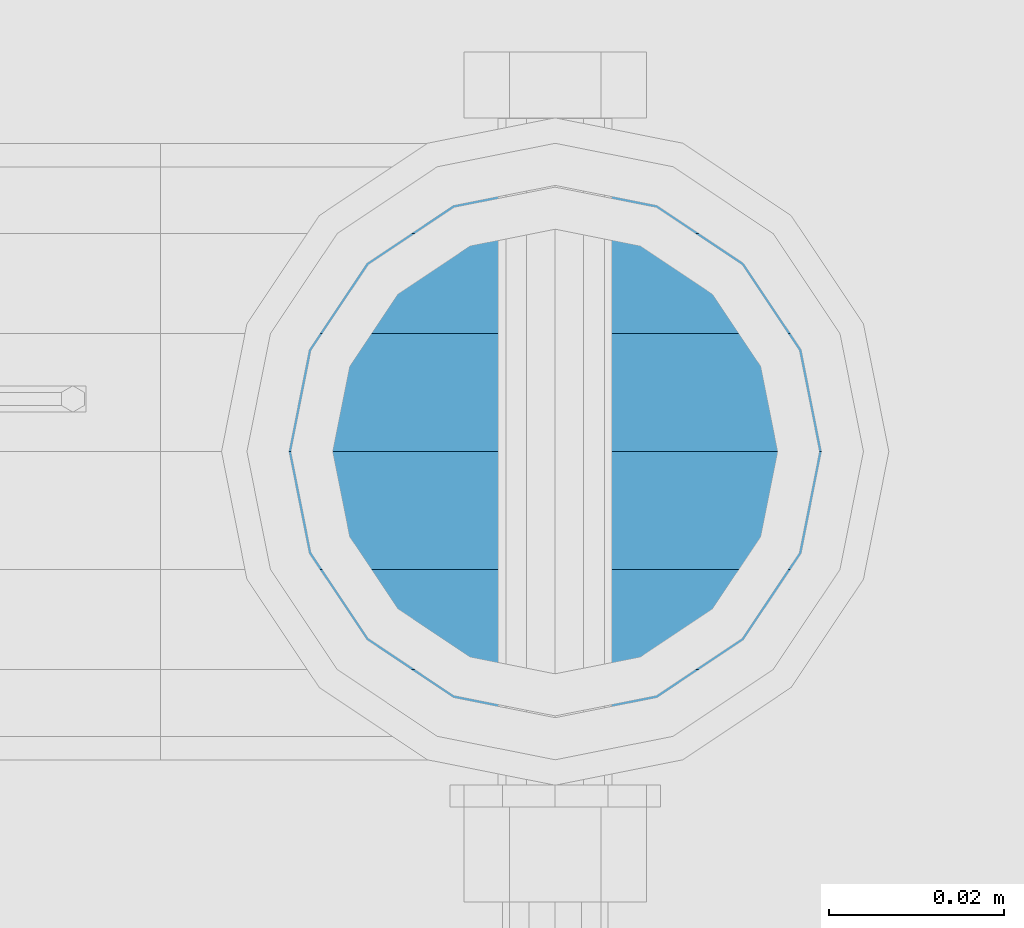
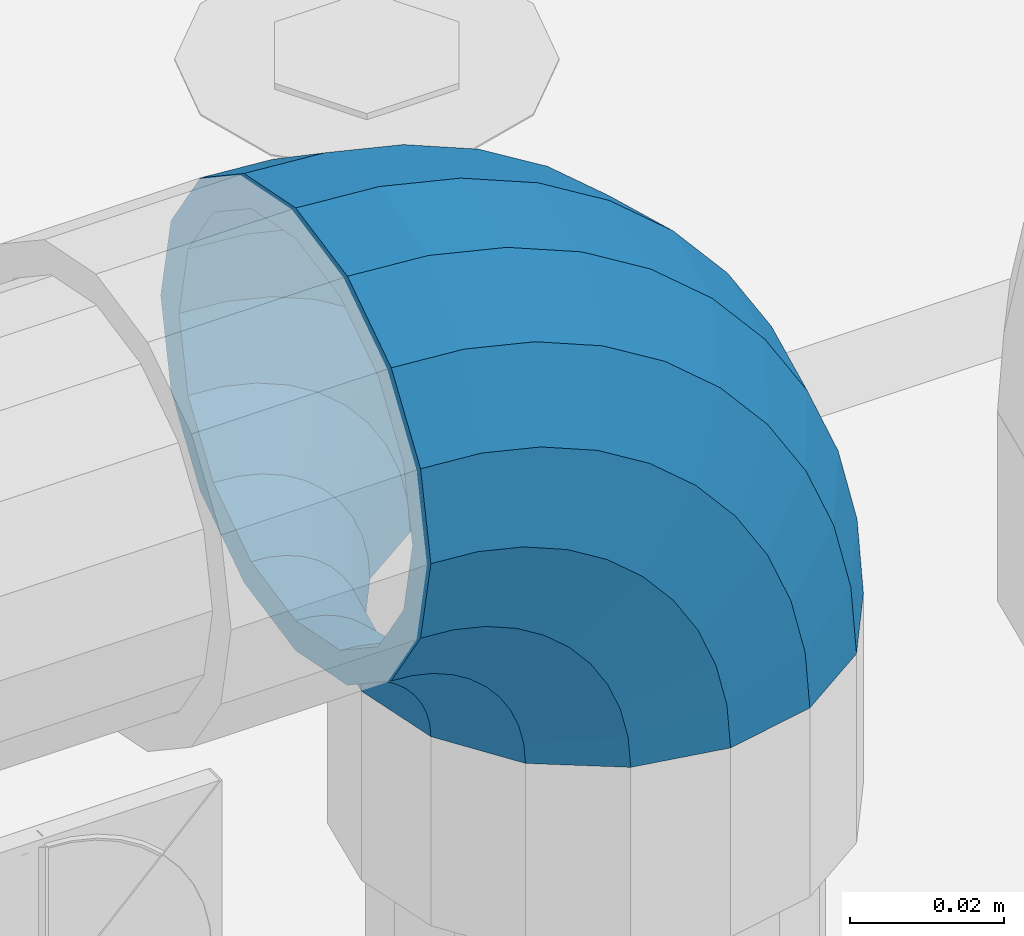
# One storey, part 138 of 208: 1 member.
"""IFC2X3 building model written with IfcOpenShell, lengths in millimetres."""

from ifc_helpers import new_model, si_unit, frame, origin_with_axes, place, context, subcontext, project, spatial, faceted_brep, material, type_object, element, save


model = new_model("IFC2X3")

# Units and contexts
model_context = context("Model", 3, precision=1e-05, world=origin_with_axes())
body_context = subcontext(model_context, "Body", "Model", "MODEL_VIEW")
ifc_project = project(units=[si_unit("LENGTHUNIT", "METRE", prefix="MILLI"), si_unit("AREAUNIT", "SQUARE_METRE"), si_unit("VOLUMEUNIT", "CUBIC_METRE"), si_unit("MASSUNIT", "GRAM", prefix="KILO"), si_unit("TIMEUNIT", "SECOND"), si_unit("PLANEANGLEUNIT", "RADIAN"), si_unit("SOLIDANGLEUNIT", "STERADIAN"), si_unit("THERMODYNAMICTEMPERATUREUNIT", "DEGREE_CELSIUS"), si_unit("LUMINOUSINTENSITYUNIT", "LUMEN")], contexts=[model_context])

# Site, building, storey
site_placement = place(None, origin_with_axes())
site = spatial("IfcSite", under=ifc_project, at=site_placement, CompositionType="ELEMENT")
building_placement = place(site_placement, origin_with_axes())
building = spatial("IfcBuilding", under=site, at=building_placement, Name="Standard", CompositionType="ELEMENT")
storey_placement = place(building_placement, origin_with_axes())
storey = spatial("IfcBuildingStorey", under=building, at=storey_placement, Name="Undefined", CompositionType="ELEMENT", Elevation=0.0)

# Member
ifc_material = material(Name="Misc_Undefined")
member_type = type_object("IfcMemberType", PredefinedType="NOTDEFINED")
member_placement = place(storey_placement, frame((-27429.0, 4664.5, 924.85), z_axis=(0.707106781186539, -1.49999999888231e-07, 0.70710678118654), x_axis=(-0.707106781186548, 0.0, 0.707106781186548)))
element("IfcMember", 1, at=member_placement, inside=storey, type_object=member_type, material=ifc_material, context=body_context, shape_type="Brep", body=[
    faceted_brep([(0.0, -35.1499999999996, 0.0), (9.51152146007371, -32.4743655677721, -9.51152146006643), (13.2759578763435, -32.4743655677721, -6.29638902527222), (5.3694688002397, -35.1499999999996, 4.58595959348168), (17.5750000000044, -24.8548033587067, -17.5749999999971), (19.9787556631163, -24.8548033587067, -15.5219987155615), (22.9628441077075, -13.4513226476329, -22.9628441076966), (24.4574219585302, -13.4513226476329, -21.6863540323902), (24.854803358714, 0.0, -24.8548033587031), (26.0301204183197, 0.0, -23.8509877588003), (22.9628441077075, 13.4513226476329, -22.9628441076966), (24.4574219585302, 13.4513226476329, -21.6863540323902), (17.5750000000044, 24.8548033587067, -17.5749999999971), (19.9787556631163, 24.8548033587067, -15.5219987155615), (9.51152146007371, 32.4743655677721, -9.51152146006643), (13.2759578763435, 32.4743655677721, -6.29638902527222), (0.0, 35.1499999999996, 0.0), (5.3694688002397, 35.1499999999996, 4.58595959348168), (-9.51152146006643, 32.4743655677721, 9.51152146007371), (-2.53702027587133, 32.4743655677721, 15.4683082122356), (-17.5749999999935, 24.8548033587067, 17.5750000000044), (-9.23981806264055, 24.8548033587067, 24.6939179025248), (-22.9628441076966, 13.4513226476329, 22.9628441077039), (-13.7184843580508, 13.4513226476329, 30.8582732193536), (-24.8548033587031, 0.0, 24.854803358714), (-15.2911828178439, 0.0, 33.02290694576), (-22.9628441076966, -13.4513226476329, 22.9628441077039), (-13.7184843580508, -13.4513226476329, 30.8582732193536), (-17.5749999999935, -24.8548033587067, 17.5750000000044), (-9.23981806264055, -24.8548033587067, 24.6939179025248), (-9.51152146006643, -32.4743655677721, 9.51152146007371), (-2.53702027587133, -32.4743655677721, 15.4683082122356), (0.0, -30.3500000000004, 0.0), (-8.21265081971433, -28.0397438117179, 8.21265081972524), (-1.45732902223244, -28.0397438117179, 13.9822406910389), (5.3694688002397, -30.3500000000004, 4.58595959348168), (-15.1749999999956, -21.4606908090118, 15.1750000000029), (-7.24480876130838, -21.4606908090118, 21.9480231689995), (-19.8270929919963, -11.6144421722802, 19.8270929920036), (-11.1118790903529, -11.6144421722802, 27.2705888550809), (-21.4606908090063, 0.0, 21.4606908090136), (-12.46981360684, 0.0, 29.139625372758), (-19.8270929919963, 11.6144421722802, 19.8270929920036), (-11.1118790903529, 11.6144421722802, 27.2705888550809), (-15.1749999999956, 21.4606908090118, 15.1750000000029), (-7.24480876130838, 21.4606908090118, 21.9480231689995), (-8.21265081971433, 28.0397438117179, 8.21265081972524), (-1.45732902223244, 28.0397438117179, 13.9822406910389), (0.0, 30.3500000000004, 0.0), (5.3694688002397, 30.3500000000004, 4.58595959348168), (8.21265081972524, 28.0397438117179, -8.21265081971433), (12.1962666227082, 28.0397438117179, -4.81032150407918), (15.1750000000029, 21.4606908090118, -15.1749999999956), (17.9837463617841, 21.4606908090118, -12.7761039820325), (19.8270929920036, 11.6144421722802, -19.8270929919963), (21.850816690825, 11.6144421722802, -18.0986696681175), (21.4606908090136, 0.0, -21.4606908090063), (23.2087512073158, 0.0, -19.9677061857983), (19.8270929920036, -11.6144421722802, -19.8270929919963), (21.850816690825, -11.6144421722802, -18.0986696681175), (15.1750000000029, -21.4606908090118, -15.1749999999956), (17.9837463617841, -21.4606908090118, -12.7761039820325), (8.21265081972524, -28.0397438117179, -8.21265081971433), (12.1962666227082, -28.0397438117179, -4.81032150407918), (17.4970053560755, -32.4743655677721, -3.70972780291777), (11.3902326651187, -35.1499999999996, 8.27548843508339), (22.6740772628655, -24.8548033587067, -13.870303514941), (26.1332861179544, -13.4513226476329, -20.6593831546779), (27.3479987309656, 0.0, -23.0433908901359), (26.1332861179544, 13.4513226476329, -20.6593831546779), (22.6740772628655, 24.8548033587067, -13.870303514941), (17.4970053560755, 32.4743655677721, -3.70972780291777), (11.3902326651187, 35.1499999999996, 8.27548843508339), (5.28345997416181, 32.4743655677721, 20.2607046730918), (0.106388067368243, 24.8548033587067, 30.4212803851115), (-3.3528207877207, 13.4513226476329, 37.2103600248483), (-4.56753340072828, 0.0, 39.59436776031), (-3.3528207877207, -13.4513226476329, 37.2103600248483), (0.106388067368243, -24.8548033587067, 30.4212803851115), (5.28345997416181, -32.4743655677721, 20.2607046730918), (6.11738625912767, -28.0397438117179, 18.6240321853948), (11.3902326651187, -30.3500000000004, 8.27548843508339), (1.64728291998108, -21.4606908090118, 27.3971039595053), (-1.33954464053022, -11.6144421722802, 33.2590831078996), (-2.38837900197541, 0.0, 35.3175364441995), (-1.33954464053022, 11.6144421722802, 33.2590831078996), (1.64728291998108, 21.4606908090118, 27.3971039595053), (6.11738625912767, 28.0397438117179, 18.6240321853948), (11.3902326651187, 30.3500000000004, 8.27548843508339), (16.663079071106, 28.0397438117179, -2.07305531522434), (21.1331824102563, 21.4606908090118, -10.8461270893349), (24.1200099707712, 11.6144421722802, -16.7081062377256), (25.1688443322128, 0.0, -18.7665595740327), (24.1200099707712, -11.6144421722802, -16.7081062377256), (21.1331824102563, -21.4606908090118, -10.8461270893349), (16.663079071106, -28.0397438117179, -2.07305531522434), (22.0707277014626, -32.4743655677721, -1.81522997692809), (17.9140404065256, -35.1499999999996, 10.9777380798914), (25.5945970362154, -24.8548033587067, -12.6605846156417), (27.9491712485142, -13.4513226476329, -19.9072189058897), (28.7759877588032, 0.0, -22.4518984678834), (27.9491712485142, 13.4513226476329, -19.9072189058897), (25.5945970362154, 24.8548033587067, -12.6605846156417), (22.0707277014626, 32.4743655677721, -1.81522997692809), (17.9140404065256, 35.1499999999996, 10.9777380798914), (13.7573531115886, 32.4743655677721, 23.7707061367109), (10.2334837768358, 24.8548033587067, 34.6160607754246), (7.87890956454066, 13.4513226476329, 41.8626950656726), (7.05209305424796, 0.0, 44.4073746276663), (7.87890956454066, -13.4513226476329, 41.8626950656726), (10.2334837768358, -24.8548033587067, 34.6160607754246), (13.7573531115886, -32.4743655677721, 23.7707061367109), (14.3249803951076, -28.0397438117179, 22.023728990971), (17.9140404065256, -30.3500000000004, 10.9777380798914), (11.2823222355146, -21.4606908090118, 31.3880679180002), (9.2492830507872, -11.6144421722802, 37.6451191472734), (8.53537462724489, 0.0, 39.8423033494473), (9.2492830507872, 11.6144421722802, 37.6451191472734), (11.2823222355146, 21.4606908090118, 31.3880679180002), (14.3249803951076, 28.0397438117179, 22.023728990971), (17.9140404065256, 30.3500000000004, 10.9777380798914), (21.5031004179436, 28.0397438117179, -0.0682528311917849), (24.5457585775366, 21.4606908090118, -9.43259175821368), (26.5787977622676, 11.6144421722802, -15.6896429874905), (27.2927061858063, 0.0, -17.8868271896645), (26.5787977622676, -11.6144421722802, -15.6896429874905), (24.5457585775366, -21.4606908090118, -9.43259175821368), (21.5031004179436, -28.0397438117179, -0.0682528311917849), (26.8845046890528, -32.4743655677721, -0.659544371261291), (24.7802542265854, -35.1499999999996, 12.6261701733893), (28.6684020936882, -24.8548033587067, -11.9226293117899), (29.860364231703, -13.4513226476329, -19.4483820661189), (30.2789256727519, 0.0, -22.0910749985305), (29.860364231703, 13.4513226476329, -19.4483820661189), (28.6684020936882, 24.8548033587067, -11.9226293117899), (26.8845046890528, 32.4743655677721, -0.659544371261291), (24.7802542265854, 35.1499999999996, 12.6261701733893), (22.6760037641179, 32.4743655677721, 25.9118847180434), (20.8921063594898, 24.8548033587067, 37.1749696585721), (19.7001442214714, 13.4513226476329, 44.7007224129011), (19.2815827804225, 0.0, 47.343415345309), (19.7001442214714, -13.4513226476329, 44.7007224129011), (20.8921063594898, -24.8548033587067, 37.1749696585721), (22.6760037641179, -32.4743655677721, 25.9118847180434), (22.9633551786246, -28.0397438117179, 24.0976192894668), (24.7802542265854, -30.3500000000004, 12.6261701733893), (21.4230625404853, -21.4606908090118, 33.8226442665691), (20.3938719035395, -11.6144421722802, 40.3206982094998), (20.0324682126193, 0.0, 42.6025113104552), (20.3938719035395, 11.6144421722802, 40.3206982094998), (21.4230625404853, 21.4606908090118, 33.8226442665691), (22.9633551786246, 28.0397438117179, 24.0976192894668), (24.7802542265854, 30.3500000000004, 12.6261701733893), (26.5971532745498, 28.0397438117179, 1.15472105731169), (28.1374459126891, 21.4606908090118, -8.5703039197906), (29.1666365496385, 11.6144421722802, -15.0683578627177), (29.5280402405588, 0.0, -17.350170963673), (29.1666365496385, -11.6144421722802, -15.0683578627177), (28.1374459126891, -21.4606908090118, -8.5703039197906), (26.5971532745498, -28.0397438117179, 1.15472105731169), (31.8198051533982, -32.4743655677721, -0.271127801024704), (31.8198051533982, -35.1499999999996, 13.1801948466091), (31.8198051533982, -24.8548033587067, -11.6746085120976), (31.8198051533982, -13.4513226476329, -19.2941707211648), (31.8198051533982, 0.0, -21.9698051533924), (31.8198051533982, 13.4513226476329, -19.2941707211648), (31.8198051533982, 24.8548033587067, -11.6746085120976), (31.8198051533982, 32.4743655677721, -0.271127801024704), (31.8198051533982, 35.1499999999996, 13.1801948466091), (31.8198051533982, 32.4743655677721, 26.6315174942429), (31.8198051533982, 24.8548033587067, 38.0349982053158), (31.8198051533946, 13.4513226476329, 45.654560414383), (31.8198051534018, 0.0, 48.3301948466105), (31.8198051533946, -13.4513226476329, 45.654560414383), (31.8198051533982, -24.8548033587067, 38.0349982053158), (31.8198051533982, -32.4743655677721, 26.6315174942429), (31.8198051533982, -28.0397438117179, 24.7946370188874), (31.8198051533982, -30.3500000000004, 13.1801948466091), (31.8198051533982, -21.4606908090118, 34.6408856556227), (31.8198051533982, -11.6144421722802, 41.219938658327), (31.8198051533982, 0.0, 43.5301948466113), (31.8198051533982, 11.6144421722802, 41.219938658327), (31.8198051533982, 21.4606908090118, 34.6408856556227), (31.8198051533982, 28.0397438117179, 24.7946370188874), (31.8198051533982, 30.3500000000004, 13.1801948466091), (31.8198051533946, 28.0397438117179, 1.56575267433072), (31.8198051533982, 21.4606908090118, -8.28049596240453), (31.8198051533982, 11.6144421722802, -14.8595489651088), (31.8198051533982, 0.0, -17.1698051533895), (31.8198051533982, -11.6144421722802, -14.8595489651088), (31.8198051533982, -21.4606908090118, -8.28049596240453), (31.8198051533946, -28.0397438117179, 1.56575267433072), (36.7551056177435, -32.4743655677721, -0.659544371261291), (38.859356080211, -35.1499999999996, 12.6261701733929), (34.9712082131082, -24.8548033587067, -11.9226293117899), (33.7792460750898, -13.4513226476329, -19.4483820661189), (33.3606846340444, 0.0, -22.0910749985269), (33.7792460750898, 13.4513226476329, -19.4483820661189), (34.9712082131082, 24.8548033587067, -11.9226293117899), (36.7551056177435, 32.4743655677721, -0.659544371261291), (38.859356080211, 35.1499999999996, 12.6261701733929), (40.9636065426712, 32.4743655677721, 25.9118847180434), (42.7475039473065, 24.8548033587067, 37.1749696585684), (43.939466085325, 13.4513226476329, 44.7007224129047), (44.3580275263703, 0.0, 47.343415345309), (43.939466085325, -13.4513226476329, 44.7007224129047), (42.7475039473065, -24.8548033587067, 37.1749696585684), (40.9636065426712, -32.4743655677721, 25.9118847180434), (40.6762551281718, -28.0397438117179, 24.0976192894668), (38.859356080211, -30.3500000000004, 12.6261701733929), (42.2165477663111, -21.4606908090118, 33.8226442665691), (43.2457384032568, -11.6144421722802, 40.3206982094998), (43.6071420941771, 0.0, 42.6025113104515), (43.2457384032568, 11.6144421722802, 40.3206982094998), (42.2165477663111, 21.4606908090118, 33.8226442665691), (40.6762551281718, 28.0397438117179, 24.0976192894668), (38.859356080211, 30.3500000000004, 12.6261701733929), (37.0424570322466, 28.0397438117179, 1.15472105731169), (35.5021643941072, 21.4606908090118, -8.5703039197906), (34.4729737571579, 11.6144421722802, -15.0683578627177), (34.1115700662376, 0.0, -17.350170963673), (34.4729737571579, -11.6144421722802, -15.0683578627177), (35.5021643941072, -21.4606908090118, -8.5703039197906), (37.0424570322466, -28.0397438117179, 1.15472105731169), (41.5688826053338, -32.4743655677721, -1.81522997692809), (45.7255699002708, -35.1499999999996, 10.9777380798914), (38.045013270581, -24.8548033587067, -12.6605846156417), (35.6904390582822, -13.4513226476329, -19.9072189058897), (34.8636225479895, 0.0, -22.4518984678834), (35.6904390582822, 13.4513226476329, -19.9072189058897), (38.045013270581, 24.8548033587067, -12.6605846156417), (41.5688826053338, 32.4743655677721, -1.81522997692809), (45.7255699002708, 35.1499999999996, 10.9777380798914), (49.8822571952114, 32.4743655677721, 23.7707061367109), (53.4061265299606, 24.8548033587067, 34.6160607754246), (55.7607007422557, 13.4513226476329, 41.8626950656726), (56.5875172525484, 0.0, 44.4073746276699), (55.7607007422557, -13.4513226476329, 41.8626950656726), (53.4061265299606, -24.8548033587067, 34.6160607754246), (49.8822571952114, -32.4743655677721, 23.7707061367109), (49.3146299116925, -28.0397438117179, 22.0237289909746), (45.7255699002708, -30.3500000000004, 10.9777380798914), (52.3572880712818, -21.4606908090118, 31.3880679179965), (54.3903272560092, -11.6144421722802, 37.6451191472697), (55.1042356795515, 0.0, 39.8423033494473), (54.3903272560092, 11.6144421722802, 37.6451191472697), (52.3572880712818, 21.4606908090118, 31.3880679179965), (49.3146299116925, 28.0397438117179, 22.0237289909746), (45.7255699002708, 30.3500000000004, 10.9777380798914), (42.1365098888527, 28.0397438117179, -0.0682528311917849), (39.0938517292598, 21.4606908090118, -9.43259175821368), (37.0608125445287, 11.6144421722802, -15.6896429874905), (36.3469041209937, 0.0, -17.8868271896645), (37.0608125445287, -11.6144421722802, -15.6896429874905), (39.0938517292598, -21.4606908090118, -9.43259175821368), (42.1365098888527, -28.0397438117179, -0.0682528311917849), (46.1426049507245, -32.4743655677721, -3.70972780291777), (52.2493776416777, -35.1499999999996, 8.27548843508339), (40.9655330439309, -24.8548033587067, -13.870303514941), (37.506324188842, -13.4513226476329, -20.6593831546743), (36.2916115758308, 0.0, -23.0433908901359), (37.506324188842, 13.4513226476329, -20.6593831546743), (40.9655330439309, 24.8548033587067, -13.870303514941), (46.1426049507245, 32.4743655677721, -3.70972780291777), (52.2493776416777, 35.1499999999996, 8.27548843508339), (58.3561503326309, 32.4743655677721, 20.2607046730918), (63.5332222394245, 24.8548033587067, 30.4212803851151), (66.9924310945171, 13.4513226476329, 37.2103600248483), (68.207143707521, 0.0, 39.5943677603063), (66.9924310945171, -13.4513226476329, 37.2103600248483), (63.5332222394245, -24.8548033587067, 30.4212803851151), (58.3561503326309, -32.4743655677721, 20.2607046730918), (57.5222240476687, -28.0397438117179, 18.6240321853984), (52.2493776416777, -30.3500000000004, 8.27548843508339), (61.9923273868153, -21.4606908090118, 27.3971039595053), (64.9791549473266, -11.6144421722802, 33.259083107896), (66.0279893087718, 0.0, 35.3175364442068), (64.9791549473266, 11.6144421722802, 33.259083107896), (61.9923273868153, 21.4606908090118, 27.3971039595053), (57.5222240476687, 28.0397438117179, 18.6240321853984), (52.2493776416777, 30.3500000000004, 8.27548843508339), (46.9765312356867, 28.0397438117179, -2.0730553152207), (42.5064278965401, 21.4606908090118, -10.8461270893349), (39.5196003360288, 11.6144421722802, -16.7081062377256), (38.4707659745836, 0.0, -18.7665595740327), (39.5196003360288, -11.6144421722802, -16.7081062377256), (42.5064278965401, -21.4606908090118, -10.8461270893349), (46.9765312356867, -28.0397438117179, -2.0730553152207), (50.3636524304529, -32.4743655677721, -6.29638902527222), (58.2701415065603, -35.1499999999996, 4.58595959348168), (43.6608546436801, -24.8548033587067, -15.5219987155615), (39.1821883482698, -13.4513226476329, -21.6863540323902), (37.6094898884767, 0.0, -23.8509877587967), (39.1821883482698, 13.4513226476329, -21.6863540323902), (43.6608546436801, 24.8548033587067, -15.5219987155615), (50.3636524304529, 32.4743655677721, -6.29638902527222), (58.2701415065603, 35.1499999999996, 4.58595959348168), (66.1766305826677, 32.4743655677721, 15.4683082122392), (72.8794283694369, 24.8548033587067, 24.6939179025212), (77.3580946648508, 13.4513226476329, 30.8582732193536), (78.9307931246403, 0.0, 33.02290694576), (77.3580946648508, -13.4513226476329, 30.8582732193536), (72.8794283694369, -24.8548033587067, 24.6939179025212), (66.1766305826677, -32.4743655677721, 15.4683082122392), (65.0969393290288, -28.0397438117179, 13.9822406910425), (58.2701415065603, -30.3500000000004, 4.58595959348168), (70.8844190681048, -21.4606908090118, 21.9480231689995), (74.7514893971456, -11.6144421722802, 27.2705888550845), (76.1094239136364, 0.0, 29.1396253727617), (74.7514893971456, 11.6144421722802, 27.2705888550845), (70.8844190681048, 21.4606908090118, 21.9480231689995), (65.0969393290288, 28.0397438117179, 13.9822406910425), (58.2701415065603, 30.3500000000004, 4.58595959348168), (51.4433436840882, 28.0397438117179, -4.81032150407918), (45.6558639450122, 21.4606908090118, -12.7761039820361), (41.7887936159714, 11.6144421722802, -18.0986696681175), (40.4308590994842, 0.0, -19.9677061857983), (41.7887936159714, -11.6144421722802, -18.0986696681175), (45.6558639450122, -21.4606908090118, -12.7761039820361), (51.4433436840882, -28.0397438117179, -4.81032150407918), (54.1280888467227, -32.4743655677721, -9.51152146006643), (63.6396103067927, -35.1499999999996, 3.63797880709171e-12), (46.064610306792, -24.8548033587067, -17.5749999999971), (40.6767661990889, -13.4513226476329, -22.9628441077002), (38.784806948086, 0.0, -24.8548033587031), (40.6767661990889, 13.4513226476329, -22.9628441077002), (46.064610306792, 24.8548033587067, -17.5749999999971), (54.1280888467227, 32.4743655677721, -9.51152146006643), (63.6396103067927, 35.1499999999996, 3.63797880709171e-12), (73.1511317668628, 32.4743655677721, 9.51152146007371), (81.2146103067935, 24.8548033587067, 17.5750000000044), (86.602454414493, 13.4513226476329, 22.9628441077075), (88.4944136654995, 0.0, 24.8548033587103), (86.602454414493, -13.4513226476329, 22.9628441077075), (81.2146103067935, -24.8548033587067, 17.5750000000044), (73.1511317668628, -32.4743655677721, 9.51152146007371), (71.8522611265107, -28.0397438117179, 8.2126508197216), (63.6396103067927, -30.3500000000004, 3.63797880709171e-12), (78.814610306792, -21.4606908090118, 15.1750000000029), (83.4667032987927, -11.6144421722802, 19.8270929920036), (85.1003011158027, 0.0, 21.4606908090136), (83.4667032987927, 11.6144421722802, 19.8270929920036), (78.814610306792, 21.4606908090118, 15.1750000000029), (71.8522611265107, 28.0397438117179, 8.2126508197216), (63.6396103067927, 30.3500000000004, 3.63797880709171e-12), (55.4269594870748, 28.0397438117179, -8.21265081971433), (48.4646103067935, 21.4606908090118, -15.1749999999956), (43.8125173147928, 11.6144421722802, -19.8270929919963), (42.1789194977791, 0.0, -21.4606908090063), (43.8125173147928, -11.6144421722802, -19.8270929919963), (48.4646103067935, -21.4606908090118, -15.1749999999956), (55.4269594870748, -28.0397438117179, -8.21265081971433)], [[[0, 1, 2, 3]], [[1, 4, 5, 2]], [[4, 6, 7, 5]], [[6, 8, 9, 7]], [[8, 10, 11, 9]], [[10, 12, 13, 11]], [[12, 14, 15, 13]], [[14, 16, 17, 15]], [[16, 18, 19, 17]], [[18, 20, 21, 19]], [[20, 22, 23, 21]], [[22, 24, 25, 23]], [[24, 26, 27, 25]], [[26, 28, 29, 27]], [[28, 30, 31, 29]], [[30, 0, 3, 31]], [[32, 33, 34, 35]], [[33, 36, 37, 34]], [[36, 38, 39, 37]], [[38, 40, 41, 39]], [[40, 42, 43, 41]], [[42, 44, 45, 43]], [[44, 46, 47, 45]], [[46, 48, 49, 47]], [[48, 50, 51, 49]], [[50, 52, 53, 51]], [[52, 54, 55, 53]], [[54, 56, 57, 55]], [[56, 58, 59, 57]], [[58, 60, 61, 59]], [[60, 62, 63, 61]], [[62, 32, 35, 63]], [[30, 28, 26, 24, 22, 20, 18, 16, 14, 12, 10, 8, 6, 4, 1, 0], [62, 60, 58, 56, 54, 52, 50, 48, 46, 44, 42, 40, 38, 36, 33, 32]], [[3, 2, 64, 65]], [[2, 5, 66, 64]], [[5, 7, 67, 66]], [[7, 9, 68, 67]], [[9, 11, 69, 68]], [[11, 13, 70, 69]], [[13, 15, 71, 70]], [[15, 17, 72, 71]], [[17, 19, 73, 72]], [[19, 21, 74, 73]], [[21, 23, 75, 74]], [[23, 25, 76, 75]], [[25, 27, 77, 76]], [[27, 29, 78, 77]], [[29, 31, 79, 78]], [[31, 3, 65, 79]], [[35, 34, 80, 81]], [[34, 37, 82, 80]], [[37, 39, 83, 82]], [[39, 41, 84, 83]], [[41, 43, 85, 84]], [[43, 45, 86, 85]], [[45, 47, 87, 86]], [[47, 49, 88, 87]], [[49, 51, 89, 88]], [[51, 53, 90, 89]], [[53, 55, 91, 90]], [[55, 57, 92, 91]], [[57, 59, 93, 92]], [[59, 61, 94, 93]], [[61, 63, 95, 94]], [[63, 35, 81, 95]], [[65, 64, 96, 97]], [[64, 66, 98, 96]], [[66, 67, 99, 98]], [[67, 68, 100, 99]], [[68, 69, 101, 100]], [[69, 70, 102, 101]], [[70, 71, 103, 102]], [[71, 72, 104, 103]], [[72, 73, 105, 104]], [[73, 74, 106, 105]], [[74, 75, 107, 106]], [[75, 76, 108, 107]], [[76, 77, 109, 108]], [[77, 78, 110, 109]], [[78, 79, 111, 110]], [[79, 65, 97, 111]], [[81, 80, 112, 113]], [[80, 82, 114, 112]], [[82, 83, 115, 114]], [[83, 84, 116, 115]], [[84, 85, 117, 116]], [[85, 86, 118, 117]], [[86, 87, 119, 118]], [[87, 88, 120, 119]], [[88, 89, 121, 120]], [[89, 90, 122, 121]], [[90, 91, 123, 122]], [[91, 92, 124, 123]], [[92, 93, 125, 124]], [[93, 94, 126, 125]], [[94, 95, 127, 126]], [[95, 81, 113, 127]], [[97, 96, 128, 129]], [[96, 98, 130, 128]], [[98, 99, 131, 130]], [[99, 100, 132, 131]], [[100, 101, 133, 132]], [[101, 102, 134, 133]], [[102, 103, 135, 134]], [[103, 104, 136, 135]], [[104, 105, 137, 136]], [[105, 106, 138, 137]], [[106, 107, 139, 138]], [[107, 108, 140, 139]], [[108, 109, 141, 140]], [[109, 110, 142, 141]], [[110, 111, 143, 142]], [[111, 97, 129, 143]], [[113, 112, 144, 145]], [[112, 114, 146, 144]], [[114, 115, 147, 146]], [[115, 116, 148, 147]], [[116, 117, 149, 148]], [[117, 118, 150, 149]], [[118, 119, 151, 150]], [[119, 120, 152, 151]], [[120, 121, 153, 152]], [[121, 122, 154, 153]], [[122, 123, 155, 154]], [[123, 124, 156, 155]], [[124, 125, 157, 156]], [[125, 126, 158, 157]], [[126, 127, 159, 158]], [[127, 113, 145, 159]], [[129, 128, 160, 161]], [[128, 130, 162, 160]], [[130, 131, 163, 162]], [[131, 132, 164, 163]], [[132, 133, 165, 164]], [[133, 134, 166, 165]], [[134, 135, 167, 166]], [[135, 136, 168, 167]], [[136, 137, 169, 168]], [[137, 138, 170, 169]], [[138, 139, 171, 170]], [[139, 140, 172, 171]], [[140, 141, 173, 172]], [[141, 142, 174, 173]], [[142, 143, 175, 174]], [[143, 129, 161, 175]], [[145, 144, 176, 177]], [[144, 146, 178, 176]], [[146, 147, 179, 178]], [[147, 148, 180, 179]], [[148, 149, 181, 180]], [[149, 150, 182, 181]], [[150, 151, 183, 182]], [[151, 152, 184, 183]], [[152, 153, 185, 184]], [[153, 154, 186, 185]], [[154, 155, 187, 186]], [[155, 156, 188, 187]], [[156, 157, 189, 188]], [[157, 158, 190, 189]], [[158, 159, 191, 190]], [[159, 145, 177, 191]], [[161, 160, 192, 193]], [[160, 162, 194, 192]], [[162, 163, 195, 194]], [[163, 164, 196, 195]], [[164, 165, 197, 196]], [[165, 166, 198, 197]], [[166, 167, 199, 198]], [[167, 168, 200, 199]], [[168, 169, 201, 200]], [[169, 170, 202, 201]], [[170, 171, 203, 202]], [[171, 172, 204, 203]], [[172, 173, 205, 204]], [[173, 174, 206, 205]], [[174, 175, 207, 206]], [[175, 161, 193, 207]], [[177, 176, 208, 209]], [[176, 178, 210, 208]], [[178, 179, 211, 210]], [[179, 180, 212, 211]], [[180, 181, 213, 212]], [[181, 182, 214, 213]], [[182, 183, 215, 214]], [[183, 184, 216, 215]], [[184, 185, 217, 216]], [[185, 186, 218, 217]], [[186, 187, 219, 218]], [[187, 188, 220, 219]], [[188, 189, 221, 220]], [[189, 190, 222, 221]], [[190, 191, 223, 222]], [[191, 177, 209, 223]], [[193, 192, 224, 225]], [[192, 194, 226, 224]], [[194, 195, 227, 226]], [[195, 196, 228, 227]], [[196, 197, 229, 228]], [[197, 198, 230, 229]], [[198, 199, 231, 230]], [[199, 200, 232, 231]], [[200, 201, 233, 232]], [[201, 202, 234, 233]], [[202, 203, 235, 234]], [[203, 204, 236, 235]], [[204, 205, 237, 236]], [[205, 206, 238, 237]], [[206, 207, 239, 238]], [[207, 193, 225, 239]], [[209, 208, 240, 241]], [[208, 210, 242, 240]], [[210, 211, 243, 242]], [[211, 212, 244, 243]], [[212, 213, 245, 244]], [[213, 214, 246, 245]], [[214, 215, 247, 246]], [[215, 216, 248, 247]], [[216, 217, 249, 248]], [[217, 218, 250, 249]], [[218, 219, 251, 250]], [[219, 220, 252, 251]], [[220, 221, 253, 252]], [[221, 222, 254, 253]], [[222, 223, 255, 254]], [[223, 209, 241, 255]], [[225, 224, 256, 257]], [[224, 226, 258, 256]], [[226, 227, 259, 258]], [[227, 228, 260, 259]], [[228, 229, 261, 260]], [[229, 230, 262, 261]], [[230, 231, 263, 262]], [[231, 232, 264, 263]], [[232, 233, 265, 264]], [[233, 234, 266, 265]], [[234, 235, 267, 266]], [[235, 236, 268, 267]], [[236, 237, 269, 268]], [[237, 238, 270, 269]], [[238, 239, 271, 270]], [[239, 225, 257, 271]], [[241, 240, 272, 273]], [[240, 242, 274, 272]], [[242, 243, 275, 274]], [[243, 244, 276, 275]], [[244, 245, 277, 276]], [[245, 246, 278, 277]], [[246, 247, 279, 278]], [[247, 248, 280, 279]], [[248, 249, 281, 280]], [[249, 250, 282, 281]], [[250, 251, 283, 282]], [[251, 252, 284, 283]], [[252, 253, 285, 284]], [[253, 254, 286, 285]], [[254, 255, 287, 286]], [[255, 241, 273, 287]], [[257, 256, 288, 289]], [[256, 258, 290, 288]], [[258, 259, 291, 290]], [[259, 260, 292, 291]], [[260, 261, 293, 292]], [[261, 262, 294, 293]], [[262, 263, 295, 294]], [[263, 264, 296, 295]], [[264, 265, 297, 296]], [[265, 266, 298, 297]], [[266, 267, 299, 298]], [[267, 268, 300, 299]], [[268, 269, 301, 300]], [[269, 270, 302, 301]], [[270, 271, 303, 302]], [[271, 257, 289, 303]], [[273, 272, 304, 305]], [[272, 274, 306, 304]], [[274, 275, 307, 306]], [[275, 276, 308, 307]], [[276, 277, 309, 308]], [[277, 278, 310, 309]], [[278, 279, 311, 310]], [[279, 280, 312, 311]], [[280, 281, 313, 312]], [[281, 282, 314, 313]], [[282, 283, 315, 314]], [[283, 284, 316, 315]], [[284, 285, 317, 316]], [[285, 286, 318, 317]], [[286, 287, 319, 318]], [[287, 273, 305, 319]], [[289, 288, 320, 321]], [[288, 290, 322, 320]], [[290, 291, 323, 322]], [[291, 292, 324, 323]], [[292, 293, 325, 324]], [[293, 294, 326, 325]], [[294, 295, 327, 326]], [[295, 296, 328, 327]], [[296, 297, 329, 328]], [[297, 298, 330, 329]], [[298, 299, 331, 330]], [[299, 300, 332, 331]], [[300, 301, 333, 332]], [[301, 302, 334, 333]], [[302, 303, 335, 334]], [[303, 289, 321, 335]], [[305, 304, 336, 337]], [[304, 306, 338, 336]], [[306, 307, 339, 338]], [[307, 308, 340, 339]], [[308, 309, 341, 340]], [[309, 310, 342, 341]], [[310, 311, 343, 342]], [[311, 312, 344, 343]], [[312, 313, 345, 344]], [[313, 314, 346, 345]], [[314, 315, 347, 346]], [[315, 316, 348, 347]], [[316, 317, 349, 348]], [[317, 318, 350, 349]], [[318, 319, 351, 350]], [[319, 305, 337, 351]], [[322, 323, 324, 325, 326, 327, 328, 329, 330, 331, 332, 333, 334, 335, 321, 320], [338, 339, 340, 341, 342, 343, 344, 345, 346, 347, 348, 349, 350, 351, 337, 336]]]),
])

save(model, "model.ifc")
